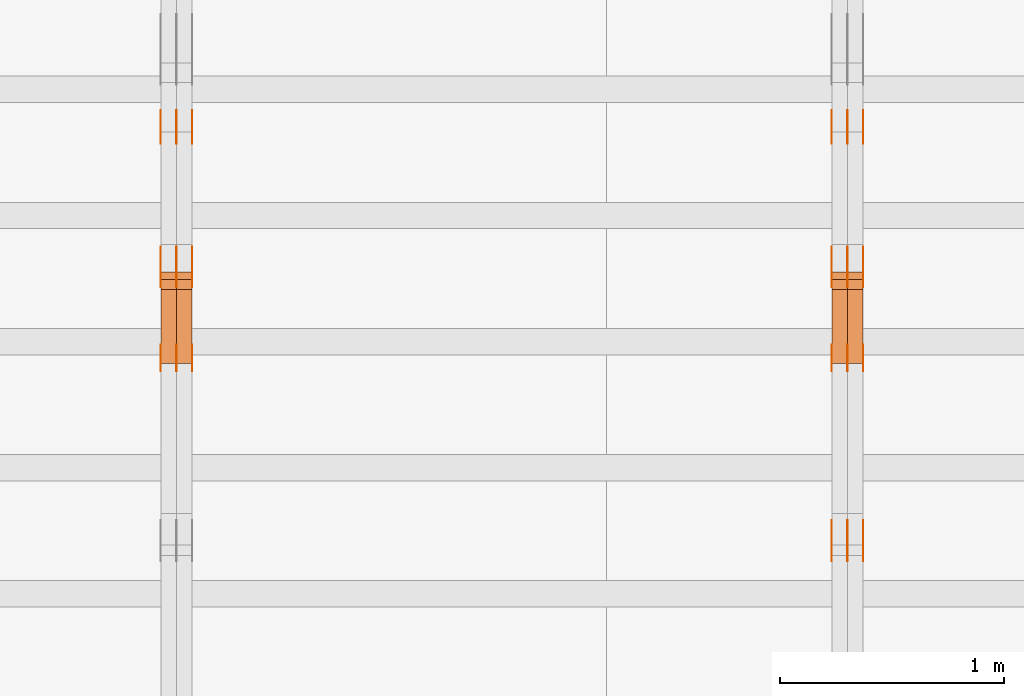
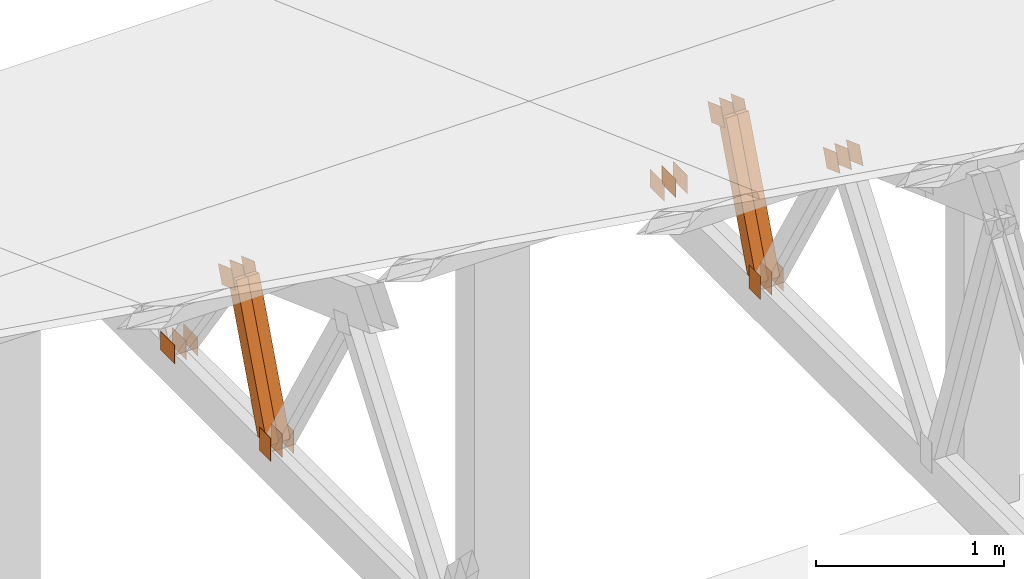
# One storey, part 127 of 189: 32 proxies.
"""IFC2X3 building model written with IfcOpenShell, lengths in millimetres."""

from ifc_helpers import new_model, entity, si_unit, converted_unit, derived_unit, direction, frame, frame_2d, origin, origin_2d_with_axis, place, context, subcontext, project, spatial, polyline, rectangle, outline, extrude, source, transform, mapped, material, type_object, type_shapes, element, save


model = new_model("IFC2X3")

# Units and contexts
model_context = context("Model", 3, precision=0.01, world=origin(), true_north=direction((6.12303176911189e-17, 1.0)))
body_context = subcontext(model_context, "Body", "Model", "MODEL_VIEW")
ifc_project = project(units=[si_unit("LENGTHUNIT", "METRE", prefix="MILLI"), si_unit("AREAUNIT", "SQUARE_METRE"), si_unit("VOLUMEUNIT", "CUBIC_METRE"), converted_unit("PLANEANGLEUNIT", "DEGREE", entity("IfcRatioMeasure", 0.0174532925199433), si_unit("PLANEANGLEUNIT", "RADIAN"), dimensions=[0, 0, 0, 0, 0, 0, 0]), si_unit("MASSUNIT", "GRAM", prefix="KILO"), derived_unit("MASSDENSITYUNIT", [(si_unit("MASSUNIT", "GRAM", prefix="KILO"), 1), (si_unit("LENGTHUNIT", "METRE"), -3)]), si_unit("TIMEUNIT", "SECOND"), si_unit("FREQUENCYUNIT", "HERTZ"), si_unit("THERMODYNAMICTEMPERATUREUNIT", "DEGREE_CELSIUS"), derived_unit("THERMALTRANSMITTANCEUNIT", [(si_unit("MASSUNIT", "GRAM", prefix="KILO"), 1), (si_unit("THERMODYNAMICTEMPERATUREUNIT", "KELVIN"), -1), (si_unit("TIMEUNIT", "SECOND"), -3)]), derived_unit("VOLUMETRICFLOWRATEUNIT", [(si_unit("LENGTHUNIT", "METRE"), 3), (si_unit("TIMEUNIT", "SECOND"), -1)]), si_unit("ELECTRICCURRENTUNIT", "AMPERE"), si_unit("ELECTRICVOLTAGEUNIT", "VOLT"), si_unit("POWERUNIT", "WATT"), si_unit("FORCEUNIT", "NEWTON"), si_unit("ILLUMINANCEUNIT", "LUX"), si_unit("LUMINOUSFLUXUNIT", "LUMEN"), si_unit("LUMINOUSINTENSITYUNIT", "CANDELA"), derived_unit("USERDEFINED", [(si_unit("MASSUNIT", "GRAM", prefix="KILO"), -1), (si_unit("LENGTHUNIT", "METRE"), -2), (si_unit("TIMEUNIT", "SECOND"), 3), (si_unit("LUMINOUSFLUXUNIT", "LUMEN"), 1)]), derived_unit("LINEARVELOCITYUNIT", [(si_unit("LENGTHUNIT", "METRE"), 1), (si_unit("TIMEUNIT", "SECOND"), -1)]), si_unit("PRESSUREUNIT", "PASCAL"), derived_unit("USERDEFINED", [(si_unit("LENGTHUNIT", "METRE"), -2), (si_unit("MASSUNIT", "GRAM", prefix="KILO"), 1), (si_unit("TIMEUNIT", "SECOND"), -2)])], contexts=[model_context])

# Site, building, storey
site_placement = place(None, origin())
site = spatial("IfcSite", under=ifc_project, at=site_placement, CompositionType="ELEMENT")
building_placement = place(site_placement, origin())
building = spatial("IfcBuilding", under=site, at=building_placement, CompositionType="ELEMENT")
storey_placement = place(building_placement, origin())
storey = spatial("IfcBuildingStorey", under=building, at=storey_placement, Name="Default", CompositionType="ELEMENT", Elevation=0.0)

# Proxies
ifc_material_1 = material(Name="IfcSurfaceStyle #105566")
building_element_proxy_type_1 = type_object("IfcBuildingElementProxyType", PredefinedType="NOTDEFINED", material=ifc_material_1)
shared_shape_1 = source(origin(), body_context, "Body", "SweptSolid", [
    extrude(outline(polyline([(-74.9999475298494, -60.0), (75.0000042257432, -60.0), (74.9999684051025, 60.0), (-75.0000251009963, 60.0), (-74.9999475298494, -60.0)])), frame((75.0000607644577, 60.0000865490217, 0.0), z_axis=(0.0, 0.0, 1.0), x_axis=(-1.0, 0.0, 0.0)), (0.0, 0.0, 1.0), 1.3),
])
type_shapes(building_element_proxy_type_1, [shared_shape_1])
proxy_1_placement = place(building_placement, frame((18301.3, 25732.0586805394, 1446.84420669249), z_axis=(-1.0, 0.0, 0.0), x_axis=(0.0, -0.939692620785908, 0.342020143325669)))
element("IfcBuildingElementProxy", 1, at=proxy_1_placement, inside=storey, type_object=building_element_proxy_type_1, material=ifc_material_1, context=body_context, shape_type="MappedRepresentation", body=[
    mapped(shared_shape_1, transform((0.0, 0.0, 0.0), scale=1.0)),
])
ifc_material_2 = material(Name="IfcSurfaceStyle #105509")
building_element_proxy_type_2 = type_object("IfcBuildingElementProxyType", PredefinedType="NOTDEFINED", material=ifc_material_2)
shared_shape_2 = source(origin(), body_context, "Body", "SweptSolid", [
    extrude(outline(polyline([(-74.9999475298494, -60.0), (75.0000042257432, -60.0), (74.9999684051025, 60.0), (-75.0000251009963, 60.0), (-74.9999475298494, -60.0)])), frame((75.0000607644577, 60.0000865490217, 0.0), z_axis=(0.0, 0.0, 1.0), x_axis=(-1.0, 0.0, 0.0)), (0.0, 0.0, 1.0), 1.29999999999999),
])
type_shapes(building_element_proxy_type_2, [shared_shape_2])
proxy_2_placement = place(building_placement, frame((18230.0, 25732.0586805394, 1446.84420669249), z_axis=(-1.0, 0.0, 0.0), x_axis=(0.0, -0.939692620785908, 0.342020143325669)))
element("IfcBuildingElementProxy", 2, at=proxy_2_placement, inside=storey, type_object=building_element_proxy_type_2, material=ifc_material_2, context=body_context, shape_type="MappedRepresentation", body=[
    mapped(shared_shape_2, transform((0.0, 0.0, 0.0), scale=1.0)),
])
ifc_material_3 = material(Name="IfcSurfaceStyle #105452")
building_element_proxy_type_3 = type_object("IfcBuildingElementProxyType", PredefinedType="NOTDEFINED", material=ifc_material_3)
shared_shape_3 = source(origin(), body_context, "Body", "SweptSolid", [
    extrude(outline(polyline([(-74.9999475298494, -60.0), (75.0000042257432, -60.0), (74.9999684051025, 60.0), (-75.0000251009963, 60.0), (-74.9999475298494, -60.0)])), frame((75.0000607644577, 60.0000865490217, 0.0), z_axis=(0.0, 0.0, 1.0), x_axis=(-1.0, 0.0, 0.0)), (0.0, 0.0, 1.0), 1.29999999999999),
])
type_shapes(building_element_proxy_type_3, [shared_shape_3])
proxy_3_placement = place(building_placement, frame((18231.3, 25732.0586805394, 1446.84420669249), z_axis=(-1.0, 0.0, 0.0), x_axis=(0.0, -0.939692620785908, 0.342020143325669)))
element("IfcBuildingElementProxy", 3, at=proxy_3_placement, inside=storey, type_object=building_element_proxy_type_3, material=ifc_material_3, context=body_context, shape_type="MappedRepresentation", body=[
    mapped(shared_shape_3, transform((0.0, 0.0, 0.0), scale=1.0)),
])
ifc_material_4 = material(Name="IfcSurfaceStyle #105395")
building_element_proxy_type_4 = type_object("IfcBuildingElementProxyType", PredefinedType="NOTDEFINED", material=ifc_material_4)
shared_shape_4 = source(origin(), body_context, "Body", "SweptSolid", [
    extrude(outline(polyline([(-74.9999475298494, -60.0), (75.0000042257432, -60.0), (74.9999684051025, 60.0), (-75.0000251009963, 60.0), (-74.9999475298494, -60.0)])), frame((75.0000607644577, 60.0000865490217, 0.0), z_axis=(0.0, 0.0, 1.0), x_axis=(-1.0, 0.0, 0.0)), (0.0, 0.0, 1.0), 1.29999999999999),
])
type_shapes(building_element_proxy_type_4, [shared_shape_4])
proxy_4_placement = place(building_placement, frame((18160.0, 25732.0586805394, 1446.84420669249), z_axis=(-1.0, 0.0, 0.0), x_axis=(0.0, -0.939692620785908, 0.342020143325669)))
element("IfcBuildingElementProxy", 4, at=proxy_4_placement, inside=storey, type_object=building_element_proxy_type_4, material=ifc_material_4, context=body_context, shape_type="MappedRepresentation", body=[
    mapped(shared_shape_4, transform((0.0, 0.0, 0.0), scale=1.0)),
])
ifc_material_5 = material(Name="IfcSurfaceStyle #105338")
building_element_proxy_type_5 = type_object("IfcBuildingElementProxyType", PredefinedType="NOTDEFINED", material=ifc_material_5)
shared_shape_5 = source(origin(), body_context, "Body", "SweptSolid", [
    extrude(rectangle(XDim=150.0, YDim=120.0, at=frame_2d((-7.105427357601e-15, 0.0), x_axis=(1.0, 0.0))), frame((75.0, 60.0, 0.0), z_axis=(0.0, 0.0, 1.0), x_axis=(-1.0, 0.0, 0.0)), (0.0, 0.0, 1.0), 1.3),
])
type_shapes(building_element_proxy_type_5, [shared_shape_5])
proxy_5_placement = place(building_placement, frame((18301.3, 26439.0083007813, 170.0), z_axis=(-1.0, 0.0, 0.0), x_axis=(0.0, 0.0, 1.0)))
element("IfcBuildingElementProxy", 5, at=proxy_5_placement, inside=storey, type_object=building_element_proxy_type_5, material=ifc_material_5, context=body_context, shape_type="MappedRepresentation", body=[
    mapped(shared_shape_5, transform((0.0, 0.0, 0.0), scale=1.0)),
])
ifc_material_6 = material(Name="IfcSurfaceStyle #105281")
building_element_proxy_type_6 = type_object("IfcBuildingElementProxyType", PredefinedType="NOTDEFINED", material=ifc_material_6)
shared_shape_6 = source(origin(), body_context, "Body", "SweptSolid", [
    extrude(rectangle(XDim=150.0, YDim=120.0, at=frame_2d((-7.105427357601e-15, 0.0), x_axis=(1.0, 0.0))), frame((75.0, 60.0, 0.0), z_axis=(0.0, 0.0, 1.0), x_axis=(-1.0, 0.0, 0.0)), (0.0, 0.0, 1.0), 1.29999999999999),
])
type_shapes(building_element_proxy_type_6, [shared_shape_6])
proxy_6_placement = place(building_placement, frame((18230.0, 26439.0083007813, 170.0), z_axis=(-1.0, 0.0, 0.0), x_axis=(0.0, 0.0, 1.0)))
element("IfcBuildingElementProxy", 6, at=proxy_6_placement, inside=storey, type_object=building_element_proxy_type_6, material=ifc_material_6, context=body_context, shape_type="MappedRepresentation", body=[
    mapped(shared_shape_6, transform((0.0, 0.0, 0.0), scale=1.0)),
])
ifc_material_7 = material(Name="IfcSurfaceStyle #105224")
building_element_proxy_type_7 = type_object("IfcBuildingElementProxyType", PredefinedType="NOTDEFINED", material=ifc_material_7)
shared_shape_7 = source(origin(), body_context, "Body", "SweptSolid", [
    extrude(rectangle(XDim=150.0, YDim=120.0, at=frame_2d((-7.105427357601e-15, 0.0), x_axis=(1.0, 0.0))), frame((75.0, 60.0, 0.0), z_axis=(0.0, 0.0, 1.0), x_axis=(-1.0, 0.0, 0.0)), (0.0, 0.0, 1.0), 1.29999999999999),
])
type_shapes(building_element_proxy_type_7, [shared_shape_7])
proxy_7_placement = place(building_placement, frame((18231.3, 26439.0083007813, 170.0), z_axis=(-1.0, 0.0, 0.0), x_axis=(0.0, 0.0, 1.0)))
element("IfcBuildingElementProxy", 7, at=proxy_7_placement, inside=storey, type_object=building_element_proxy_type_7, material=ifc_material_7, context=body_context, shape_type="MappedRepresentation", body=[
    mapped(shared_shape_7, transform((0.0, 0.0, 0.0), scale=1.0)),
])
ifc_material_8 = material(Name="IfcSurfaceStyle #105167")
building_element_proxy_type_8 = type_object("IfcBuildingElementProxyType", PredefinedType="NOTDEFINED", material=ifc_material_8)
shared_shape_8 = source(origin(), body_context, "Body", "SweptSolid", [
    extrude(rectangle(XDim=150.0, YDim=120.0, at=frame_2d((-7.105427357601e-15, 0.0), x_axis=(1.0, 0.0))), frame((75.0, 60.0, 0.0), z_axis=(0.0, 0.0, 1.0), x_axis=(-1.0, 0.0, 0.0)), (0.0, 0.0, 1.0), 1.29999999999999),
])
type_shapes(building_element_proxy_type_8, [shared_shape_8])
proxy_8_placement = place(building_placement, frame((18160.0, 26439.0083007813, 170.0), z_axis=(-1.0, 0.0, 0.0), x_axis=(0.0, 0.0, 1.0)))
element("IfcBuildingElementProxy", 8, at=proxy_8_placement, inside=storey, type_object=building_element_proxy_type_8, material=ifc_material_8, context=body_context, shape_type="MappedRepresentation", body=[
    mapped(shared_shape_8, transform((0.0, 0.0, 0.0), scale=1.0)),
])
ifc_material_9 = material(Name="IfcSurfaceStyle #104654")
building_element_proxy_type_9 = type_object("IfcBuildingElementProxyType", PredefinedType="NOTDEFINED", material=ifc_material_9)
shared_shape_9 = source(origin(), body_context, "Body", "SweptSolid", [
    extrude(outline(polyline([(-74.9999684051023, -60.0), (75.0000251009964, -60.0), (74.9999475298495, 60.0), (-75.0000042257435, 60.0), (-74.9999684051023, -60.0)])), frame((75.0000251009964, 60.0000006265238, 0.0), z_axis=(0.0, 0.0, 1.0), x_axis=(-1.0, 0.0, 0.0)), (0.0, 0.0, 1.0), 1.3),
])
type_shapes(building_element_proxy_type_9, [shared_shape_9])
proxy_9_placement = place(building_placement, frame((18301.3, 26956.490053282, 1001.18769055967), z_axis=(-1.0, 0.0, 0.0), x_axis=(0.0, -0.939692620785908, 0.342020143325669)))
element("IfcBuildingElementProxy", 9, at=proxy_9_placement, inside=storey, type_object=building_element_proxy_type_9, material=ifc_material_9, context=body_context, shape_type="MappedRepresentation", body=[
    mapped(shared_shape_9, transform((0.0, 0.0, 0.0), scale=1.0)),
])
ifc_material_10 = material(Name="IfcSurfaceStyle #104597")
building_element_proxy_type_10 = type_object("IfcBuildingElementProxyType", PredefinedType="NOTDEFINED", material=ifc_material_10)
shared_shape_10 = source(origin(), body_context, "Body", "SweptSolid", [
    extrude(outline(polyline([(-74.9999684051023, -60.0), (75.0000251009964, -60.0), (74.9999475298495, 60.0), (-75.0000042257435, 60.0), (-74.9999684051023, -60.0)])), frame((75.0000251009964, 60.0000006265238, 0.0), z_axis=(0.0, 0.0, 1.0), x_axis=(-1.0, 0.0, 0.0)), (0.0, 0.0, 1.0), 1.29999999999999),
])
type_shapes(building_element_proxy_type_10, [shared_shape_10])
proxy_10_placement = place(building_placement, frame((18230.0, 26956.490053282, 1001.18769055967), z_axis=(-1.0, 0.0, 0.0), x_axis=(0.0, -0.939692620785908, 0.342020143325669)))
element("IfcBuildingElementProxy", 10, at=proxy_10_placement, inside=storey, type_object=building_element_proxy_type_10, material=ifc_material_10, context=body_context, shape_type="MappedRepresentation", body=[
    mapped(shared_shape_10, transform((0.0, 0.0, 0.0), scale=1.0)),
])
ifc_material_11 = material(Name="IfcSurfaceStyle #104540")
building_element_proxy_type_11 = type_object("IfcBuildingElementProxyType", PredefinedType="NOTDEFINED", material=ifc_material_11)
shared_shape_11 = source(origin(), body_context, "Body", "SweptSolid", [
    extrude(outline(polyline([(-74.9999684051023, -60.0), (75.0000251009964, -60.0), (74.9999475298495, 60.0), (-75.0000042257435, 60.0), (-74.9999684051023, -60.0)])), frame((75.0000251009964, 60.0000006265238, 0.0), z_axis=(0.0, 0.0, 1.0), x_axis=(-1.0, 0.0, 0.0)), (0.0, 0.0, 1.0), 1.29999999999999),
])
type_shapes(building_element_proxy_type_11, [shared_shape_11])
proxy_11_placement = place(building_placement, frame((18231.3, 26956.490053282, 1001.18769055967), z_axis=(-1.0, 0.0, 0.0), x_axis=(0.0, -0.939692620785908, 0.342020143325669)))
element("IfcBuildingElementProxy", 11, at=proxy_11_placement, inside=storey, type_object=building_element_proxy_type_11, material=ifc_material_11, context=body_context, shape_type="MappedRepresentation", body=[
    mapped(shared_shape_11, transform((0.0, 0.0, 0.0), scale=1.0)),
])
ifc_material_12 = material(Name="IfcSurfaceStyle #104483")
building_element_proxy_type_12 = type_object("IfcBuildingElementProxyType", PredefinedType="NOTDEFINED", material=ifc_material_12)
shared_shape_12 = source(origin(), body_context, "Body", "SweptSolid", [
    extrude(outline(polyline([(-74.9999684051023, -60.0), (75.0000251009964, -60.0), (74.9999475298495, 60.0), (-75.0000042257435, 60.0), (-74.9999684051023, -60.0)])), frame((75.0000251009964, 60.0000006265238, 0.0), z_axis=(0.0, 0.0, 1.0), x_axis=(-1.0, 0.0, 0.0)), (0.0, 0.0, 1.0), 1.29999999999999),
])
type_shapes(building_element_proxy_type_12, [shared_shape_12])
proxy_12_placement = place(building_placement, frame((18160.0, 26956.490053282, 1001.18769055967), z_axis=(-1.0, 0.0, 0.0), x_axis=(0.0, -0.939692620785908, 0.342020143325669)))
element("IfcBuildingElementProxy", 12, at=proxy_12_placement, inside=storey, type_object=building_element_proxy_type_12, material=ifc_material_12, context=body_context, shape_type="MappedRepresentation", body=[
    mapped(shared_shape_12, transform((0.0, 0.0, 0.0), scale=1.0)),
])
ifc_material_13 = material(Name="IfcSurfaceStyle #104426")
building_element_proxy_type_13 = type_object("IfcBuildingElementProxyType", PredefinedType="NOTDEFINED", material=ifc_material_13)
shared_shape_13 = source(origin(), body_context, "Body", "SweptSolid", [
    extrude(rectangle(XDim=150.0, YDim=120.0, at=origin_2d_with_axis()), frame((75.0, 60.0, 0.0), z_axis=(0.0, 0.0, 1.0), x_axis=(-1.0, 0.0, 0.0)), (0.0, 0.0, 1.0), 1.3),
])
type_shapes(building_element_proxy_type_13, [shared_shape_13])
proxy_13_placement = place(building_placement, frame((18301.3, 27607.3129882813, 185.0), z_axis=(-1.0, 0.0, 0.0), x_axis=(0.0, -1.0, 0.0)))
element("IfcBuildingElementProxy", 13, at=proxy_13_placement, inside=storey, type_object=building_element_proxy_type_13, material=ifc_material_13, context=body_context, shape_type="MappedRepresentation", body=[
    mapped(shared_shape_13, transform((0.0, 0.0, 0.0), scale=1.0)),
])
ifc_material_14 = material(Name="IfcSurfaceStyle #104369")
building_element_proxy_type_14 = type_object("IfcBuildingElementProxyType", PredefinedType="NOTDEFINED", material=ifc_material_14)
shared_shape_14 = source(origin(), body_context, "Body", "SweptSolid", [
    extrude(rectangle(XDim=150.0, YDim=120.0, at=origin_2d_with_axis()), frame((75.0, 60.0, 0.0), z_axis=(0.0, 0.0, 1.0), x_axis=(-1.0, 0.0, 0.0)), (0.0, 0.0, 1.0), 1.29999999999999),
])
type_shapes(building_element_proxy_type_14, [shared_shape_14])
proxy_14_placement = place(building_placement, frame((18230.0, 27607.3129882813, 185.0), z_axis=(-1.0, 0.0, 0.0), x_axis=(0.0, -1.0, 0.0)))
element("IfcBuildingElementProxy", 14, at=proxy_14_placement, inside=storey, type_object=building_element_proxy_type_14, material=ifc_material_14, context=body_context, shape_type="MappedRepresentation", body=[
    mapped(shared_shape_14, transform((0.0, 0.0, 0.0), scale=1.0)),
])
ifc_material_15 = material(Name="IfcSurfaceStyle #104312")
building_element_proxy_type_15 = type_object("IfcBuildingElementProxyType", PredefinedType="NOTDEFINED", material=ifc_material_15)
shared_shape_15 = source(origin(), body_context, "Body", "SweptSolid", [
    extrude(rectangle(XDim=150.0, YDim=120.0, at=origin_2d_with_axis()), frame((75.0, 60.0, 0.0), z_axis=(0.0, 0.0, 1.0), x_axis=(-1.0, 0.0, 0.0)), (0.0, 0.0, 1.0), 1.29999999999999),
])
type_shapes(building_element_proxy_type_15, [shared_shape_15])
proxy_15_placement = place(building_placement, frame((18231.3, 27607.3129882813, 185.0), z_axis=(-1.0, 0.0, 0.0), x_axis=(0.0, -1.0, 0.0)))
element("IfcBuildingElementProxy", 15, at=proxy_15_placement, inside=storey, type_object=building_element_proxy_type_15, material=ifc_material_15, context=body_context, shape_type="MappedRepresentation", body=[
    mapped(shared_shape_15, transform((0.0, 0.0, 0.0), scale=1.0)),
])
ifc_material_16 = material(Name="IfcSurfaceStyle #104255")
building_element_proxy_type_16 = type_object("IfcBuildingElementProxyType", PredefinedType="NOTDEFINED", material=ifc_material_16)
shared_shape_16 = source(origin(), body_context, "Body", "SweptSolid", [
    extrude(rectangle(XDim=150.0, YDim=120.0, at=origin_2d_with_axis()), frame((75.0, 60.0, 0.0), z_axis=(0.0, 0.0, 1.0), x_axis=(-1.0, 0.0, 0.0)), (0.0, 0.0, 1.0), 1.29999999999999),
])
type_shapes(building_element_proxy_type_16, [shared_shape_16])
proxy_16_placement = place(building_placement, frame((18160.0, 27607.3129882813, 185.0), z_axis=(-1.0, 0.0, 0.0), x_axis=(0.0, -1.0, 0.0)))
element("IfcBuildingElementProxy", 16, at=proxy_16_placement, inside=storey, type_object=building_element_proxy_type_16, material=ifc_material_16, context=body_context, shape_type="MappedRepresentation", body=[
    mapped(shared_shape_16, transform((0.0, 0.0, 0.0), scale=1.0)),
])
ifc_material_17 = material(Name="IfcSurfaceStyle #97178")
building_element_proxy_type_17 = type_object("IfcBuildingElementProxyType", Name="T1-W14 97176", PredefinedType="NOTDEFINED", material=ifc_material_17)
shared_shape_17 = source(origin(), body_context, "Body", "SweptSolid", [
    extrude(outline(polyline([(-561.981237417233, -47.499947472121), (373.092610496013, -47.499947472121), (373.679602940405, -4.61719047935016e-05), (341.277449358876, 47.4999705580734), (-526.068425378061, 47.4999705580734), (-561.981237417233, -47.499947472121)])), frame((373.679632439416, 47.500120814091, 0.0), z_axis=(0.0, 0.0, 1.0), x_axis=(-1.0, 0.0, 0.0)), (0.0, 0.0, 1.0), 69.9999999999999),
])
type_shapes(building_element_proxy_type_17, [shared_shape_17])
proxy_17_placement = place(building_placement, frame((18300.0, 26895.4809555667, 1086.61918844835), z_axis=(-1.0, 0.0, 0.0), x_axis=(0.0, -0.353606472447933, -0.935394281916951)))
element("IfcBuildingElementProxy", 17, at=proxy_17_placement, inside=storey, type_object=building_element_proxy_type_17, material=ifc_material_17, Name="T1-W14", context=body_context, shape_type="MappedRepresentation", body=[
    mapped(shared_shape_17, transform((0.0, 0.0, 0.0), scale=1.0)),
])
ifc_material_18 = material(Name="IfcSurfaceStyle #97112")
building_element_proxy_type_18 = type_object("IfcBuildingElementProxyType", Name="T1-W14 97110", PredefinedType="NOTDEFINED", material=ifc_material_18)
shared_shape_18 = source(origin(), body_context, "Body", "SweptSolid", [
    extrude(outline(polyline([(-561.981237417233, -47.499947472121), (373.092610496013, -47.499947472121), (373.679602940405, -4.61719047935016e-05), (341.277449358876, 47.4999705580734), (-526.068425378061, 47.4999705580734), (-561.981237417233, -47.499947472121)])), frame((373.679632439416, 47.500120814091, 0.0), z_axis=(0.0, 0.0, 1.0), x_axis=(-1.0, 0.0, 0.0)), (0.0, 0.0, 1.0), 69.9999999999999),
])
type_shapes(building_element_proxy_type_18, [shared_shape_18])
proxy_18_placement = place(building_placement, frame((18230.0, 26895.4809555667, 1086.61918844835), z_axis=(-1.0, 0.0, 0.0), x_axis=(0.0, -0.353606472447933, -0.935394281916951)))
element("IfcBuildingElementProxy", 18, at=proxy_18_placement, inside=storey, type_object=building_element_proxy_type_18, material=ifc_material_18, Name="T1-W14", context=body_context, shape_type="MappedRepresentation", body=[
    mapped(shared_shape_18, transform((0.0, 0.0, 0.0), scale=1.0)),
])
ifc_material_19 = material(Name="IfcSurfaceStyle #89548")
building_element_proxy_type_19 = type_object("IfcBuildingElementProxyType", PredefinedType="NOTDEFINED", material=ifc_material_19)
shared_shape_19 = source(origin(), body_context, "Body", "SweptSolid", [
    extrude(rectangle(XDim=150.0, YDim=120.0, at=frame_2d((-7.105427357601e-15, 0.0), x_axis=(1.0, 0.0))), frame((75.0, 60.0, 0.0), z_axis=(0.0, 0.0, 1.0), x_axis=(-1.0, 0.0, 0.0)), (0.0, 0.0, 1.0), 1.3),
])
type_shapes(building_element_proxy_type_19, [shared_shape_19])
proxy_19_placement = place(building_placement, frame((15301.3, 26439.0083007813, 170.0), z_axis=(-1.0, 0.0, 0.0), x_axis=(0.0, 0.0, 1.0)))
element("IfcBuildingElementProxy", 19, at=proxy_19_placement, inside=storey, type_object=building_element_proxy_type_19, material=ifc_material_19, context=body_context, shape_type="MappedRepresentation", body=[
    mapped(shared_shape_19, transform((0.0, 0.0, 0.0), scale=1.0)),
])
ifc_material_20 = material(Name="IfcSurfaceStyle #89491")
building_element_proxy_type_20 = type_object("IfcBuildingElementProxyType", PredefinedType="NOTDEFINED", material=ifc_material_20)
shared_shape_20 = source(origin(), body_context, "Body", "SweptSolid", [
    extrude(rectangle(XDim=150.0, YDim=120.0, at=frame_2d((-7.105427357601e-15, 0.0), x_axis=(1.0, 0.0))), frame((75.0, 60.0, 0.0), z_axis=(0.0, 0.0, 1.0), x_axis=(-1.0, 0.0, 0.0)), (0.0, 0.0, 1.0), 1.29999999999999),
])
type_shapes(building_element_proxy_type_20, [shared_shape_20])
proxy_20_placement = place(building_placement, frame((15230.0, 26439.0083007813, 170.0), z_axis=(-1.0, 0.0, 0.0), x_axis=(0.0, 0.0, 1.0)))
element("IfcBuildingElementProxy", 20, at=proxy_20_placement, inside=storey, type_object=building_element_proxy_type_20, material=ifc_material_20, context=body_context, shape_type="MappedRepresentation", body=[
    mapped(shared_shape_20, transform((0.0, 0.0, 0.0), scale=1.0)),
])
ifc_material_21 = material(Name="IfcSurfaceStyle #89434")
building_element_proxy_type_21 = type_object("IfcBuildingElementProxyType", PredefinedType="NOTDEFINED", material=ifc_material_21)
shared_shape_21 = source(origin(), body_context, "Body", "SweptSolid", [
    extrude(rectangle(XDim=150.0, YDim=120.0, at=frame_2d((-7.105427357601e-15, 0.0), x_axis=(1.0, 0.0))), frame((75.0, 60.0, 0.0), z_axis=(0.0, 0.0, 1.0), x_axis=(-1.0, 0.0, 0.0)), (0.0, 0.0, 1.0), 1.29999999999999),
])
type_shapes(building_element_proxy_type_21, [shared_shape_21])
proxy_21_placement = place(building_placement, frame((15231.3, 26439.0083007813, 170.0), z_axis=(-1.0, 0.0, 0.0), x_axis=(0.0, 0.0, 1.0)))
element("IfcBuildingElementProxy", 21, at=proxy_21_placement, inside=storey, type_object=building_element_proxy_type_21, material=ifc_material_21, context=body_context, shape_type="MappedRepresentation", body=[
    mapped(shared_shape_21, transform((0.0, 0.0, 0.0), scale=1.0)),
])
ifc_material_22 = material(Name="IfcSurfaceStyle #89377")
building_element_proxy_type_22 = type_object("IfcBuildingElementProxyType", PredefinedType="NOTDEFINED", material=ifc_material_22)
shared_shape_22 = source(origin(), body_context, "Body", "SweptSolid", [
    extrude(rectangle(XDim=150.0, YDim=120.0, at=frame_2d((-7.105427357601e-15, 0.0), x_axis=(1.0, 0.0))), frame((75.0, 60.0, 0.0), z_axis=(0.0, 0.0, 1.0), x_axis=(-1.0, 0.0, 0.0)), (0.0, 0.0, 1.0), 1.29999999999999),
])
type_shapes(building_element_proxy_type_22, [shared_shape_22])
proxy_22_placement = place(building_placement, frame((15160.0, 26439.0083007813, 170.0), z_axis=(-1.0, 0.0, 0.0), x_axis=(0.0, 0.0, 1.0)))
element("IfcBuildingElementProxy", 22, at=proxy_22_placement, inside=storey, type_object=building_element_proxy_type_22, material=ifc_material_22, context=body_context, shape_type="MappedRepresentation", body=[
    mapped(shared_shape_22, transform((0.0, 0.0, 0.0), scale=1.0)),
])
ifc_material_23 = material(Name="IfcSurfaceStyle #88864")
building_element_proxy_type_23 = type_object("IfcBuildingElementProxyType", PredefinedType="NOTDEFINED", material=ifc_material_23)
shared_shape_23 = source(origin(), body_context, "Body", "SweptSolid", [
    extrude(outline(polyline([(-74.9999684051023, -60.0), (75.0000251009964, -60.0), (74.9999475298495, 60.0), (-75.0000042257435, 60.0), (-74.9999684051023, -60.0)])), frame((75.0000251009964, 60.0000006265238, 0.0), z_axis=(0.0, 0.0, 1.0), x_axis=(-1.0, 0.0, 0.0)), (0.0, 0.0, 1.0), 1.3),
])
type_shapes(building_element_proxy_type_23, [shared_shape_23])
proxy_23_placement = place(building_placement, frame((15301.3, 26956.490053282, 1001.18769055967), z_axis=(-1.0, 0.0, 0.0), x_axis=(0.0, -0.939692620785908, 0.342020143325669)))
element("IfcBuildingElementProxy", 23, at=proxy_23_placement, inside=storey, type_object=building_element_proxy_type_23, material=ifc_material_23, context=body_context, shape_type="MappedRepresentation", body=[
    mapped(shared_shape_23, transform((0.0, 0.0, 0.0), scale=1.0)),
])
ifc_material_24 = material(Name="IfcSurfaceStyle #88807")
building_element_proxy_type_24 = type_object("IfcBuildingElementProxyType", PredefinedType="NOTDEFINED", material=ifc_material_24)
shared_shape_24 = source(origin(), body_context, "Body", "SweptSolid", [
    extrude(outline(polyline([(-74.9999684051023, -60.0), (75.0000251009964, -60.0), (74.9999475298495, 60.0), (-75.0000042257435, 60.0), (-74.9999684051023, -60.0)])), frame((75.0000251009964, 60.0000006265238, 0.0), z_axis=(0.0, 0.0, 1.0), x_axis=(-1.0, 0.0, 0.0)), (0.0, 0.0, 1.0), 1.29999999999999),
])
type_shapes(building_element_proxy_type_24, [shared_shape_24])
proxy_24_placement = place(building_placement, frame((15230.0, 26956.490053282, 1001.18769055967), z_axis=(-1.0, 0.0, 0.0), x_axis=(0.0, -0.939692620785908, 0.342020143325669)))
element("IfcBuildingElementProxy", 24, at=proxy_24_placement, inside=storey, type_object=building_element_proxy_type_24, material=ifc_material_24, context=body_context, shape_type="MappedRepresentation", body=[
    mapped(shared_shape_24, transform((0.0, 0.0, 0.0), scale=1.0)),
])
ifc_material_25 = material(Name="IfcSurfaceStyle #88750")
building_element_proxy_type_25 = type_object("IfcBuildingElementProxyType", PredefinedType="NOTDEFINED", material=ifc_material_25)
shared_shape_25 = source(origin(), body_context, "Body", "SweptSolid", [
    extrude(outline(polyline([(-74.9999684051023, -60.0), (75.0000251009964, -60.0), (74.9999475298495, 60.0), (-75.0000042257435, 60.0), (-74.9999684051023, -60.0)])), frame((75.0000251009964, 60.0000006265238, 0.0), z_axis=(0.0, 0.0, 1.0), x_axis=(-1.0, 0.0, 0.0)), (0.0, 0.0, 1.0), 1.29999999999999),
])
type_shapes(building_element_proxy_type_25, [shared_shape_25])
proxy_25_placement = place(building_placement, frame((15231.3, 26956.490053282, 1001.18769055967), z_axis=(-1.0, 0.0, 0.0), x_axis=(0.0, -0.939692620785908, 0.342020143325669)))
element("IfcBuildingElementProxy", 25, at=proxy_25_placement, inside=storey, type_object=building_element_proxy_type_25, material=ifc_material_25, context=body_context, shape_type="MappedRepresentation", body=[
    mapped(shared_shape_25, transform((0.0, 0.0, 0.0), scale=1.0)),
])
ifc_material_26 = material(Name="IfcSurfaceStyle #88693")
building_element_proxy_type_26 = type_object("IfcBuildingElementProxyType", PredefinedType="NOTDEFINED", material=ifc_material_26)
shared_shape_26 = source(origin(), body_context, "Body", "SweptSolid", [
    extrude(outline(polyline([(-74.9999684051023, -60.0), (75.0000251009964, -60.0), (74.9999475298495, 60.0), (-75.0000042257435, 60.0), (-74.9999684051023, -60.0)])), frame((75.0000251009964, 60.0000006265238, 0.0), z_axis=(0.0, 0.0, 1.0), x_axis=(-1.0, 0.0, 0.0)), (0.0, 0.0, 1.0), 1.29999999999999),
])
type_shapes(building_element_proxy_type_26, [shared_shape_26])
proxy_26_placement = place(building_placement, frame((15160.0, 26956.490053282, 1001.18769055967), z_axis=(-1.0, 0.0, 0.0), x_axis=(0.0, -0.939692620785908, 0.342020143325669)))
element("IfcBuildingElementProxy", 26, at=proxy_26_placement, inside=storey, type_object=building_element_proxy_type_26, material=ifc_material_26, context=body_context, shape_type="MappedRepresentation", body=[
    mapped(shared_shape_26, transform((0.0, 0.0, 0.0), scale=1.0)),
])
ifc_material_27 = material(Name="IfcSurfaceStyle #88636")
building_element_proxy_type_27 = type_object("IfcBuildingElementProxyType", PredefinedType="NOTDEFINED", material=ifc_material_27)
shared_shape_27 = source(origin(), body_context, "Body", "SweptSolid", [
    extrude(rectangle(XDim=150.0, YDim=120.0, at=origin_2d_with_axis()), frame((75.0, 60.0, 0.0), z_axis=(0.0, 0.0, 1.0), x_axis=(-1.0, 0.0, 0.0)), (0.0, 0.0, 1.0), 1.3),
])
type_shapes(building_element_proxy_type_27, [shared_shape_27])
proxy_27_placement = place(building_placement, frame((15301.3, 27607.3129882813, 185.0), z_axis=(-1.0, 0.0, 0.0), x_axis=(0.0, -1.0, 0.0)))
element("IfcBuildingElementProxy", 27, at=proxy_27_placement, inside=storey, type_object=building_element_proxy_type_27, material=ifc_material_27, context=body_context, shape_type="MappedRepresentation", body=[
    mapped(shared_shape_27, transform((0.0, 0.0, 0.0), scale=1.0)),
])
ifc_material_28 = material(Name="IfcSurfaceStyle #88579")
building_element_proxy_type_28 = type_object("IfcBuildingElementProxyType", PredefinedType="NOTDEFINED", material=ifc_material_28)
shared_shape_28 = source(origin(), body_context, "Body", "SweptSolid", [
    extrude(rectangle(XDim=150.0, YDim=120.0, at=origin_2d_with_axis()), frame((75.0, 60.0, 0.0), z_axis=(0.0, 0.0, 1.0), x_axis=(-1.0, 0.0, 0.0)), (0.0, 0.0, 1.0), 1.29999999999999),
])
type_shapes(building_element_proxy_type_28, [shared_shape_28])
proxy_28_placement = place(building_placement, frame((15230.0, 27607.3129882813, 185.0), z_axis=(-1.0, 0.0, 0.0), x_axis=(0.0, -1.0, 0.0)))
element("IfcBuildingElementProxy", 28, at=proxy_28_placement, inside=storey, type_object=building_element_proxy_type_28, material=ifc_material_28, context=body_context, shape_type="MappedRepresentation", body=[
    mapped(shared_shape_28, transform((0.0, 0.0, 0.0), scale=1.0)),
])
ifc_material_29 = material(Name="IfcSurfaceStyle #88522")
building_element_proxy_type_29 = type_object("IfcBuildingElementProxyType", PredefinedType="NOTDEFINED", material=ifc_material_29)
shared_shape_29 = source(origin(), body_context, "Body", "SweptSolid", [
    extrude(rectangle(XDim=150.0, YDim=120.0, at=origin_2d_with_axis()), frame((75.0, 60.0, 0.0), z_axis=(0.0, 0.0, 1.0), x_axis=(-1.0, 0.0, 0.0)), (0.0, 0.0, 1.0), 1.29999999999999),
])
type_shapes(building_element_proxy_type_29, [shared_shape_29])
proxy_29_placement = place(building_placement, frame((15231.3, 27607.3129882813, 185.0), z_axis=(-1.0, 0.0, 0.0), x_axis=(0.0, -1.0, 0.0)))
element("IfcBuildingElementProxy", 29, at=proxy_29_placement, inside=storey, type_object=building_element_proxy_type_29, material=ifc_material_29, context=body_context, shape_type="MappedRepresentation", body=[
    mapped(shared_shape_29, transform((0.0, 0.0, 0.0), scale=1.0)),
])
ifc_material_30 = material(Name="IfcSurfaceStyle #88465")
building_element_proxy_type_30 = type_object("IfcBuildingElementProxyType", PredefinedType="NOTDEFINED", material=ifc_material_30)
shared_shape_30 = source(origin(), body_context, "Body", "SweptSolid", [
    extrude(rectangle(XDim=150.0, YDim=120.0, at=origin_2d_with_axis()), frame((75.0, 60.0, 0.0), z_axis=(0.0, 0.0, 1.0), x_axis=(-1.0, 0.0, 0.0)), (0.0, 0.0, 1.0), 1.29999999999999),
])
type_shapes(building_element_proxy_type_30, [shared_shape_30])
proxy_30_placement = place(building_placement, frame((15160.0, 27607.3129882813, 185.0), z_axis=(-1.0, 0.0, 0.0), x_axis=(0.0, -1.0, 0.0)))
element("IfcBuildingElementProxy", 30, at=proxy_30_placement, inside=storey, type_object=building_element_proxy_type_30, material=ifc_material_30, context=body_context, shape_type="MappedRepresentation", body=[
    mapped(shared_shape_30, transform((0.0, 0.0, 0.0), scale=1.0)),
])
ifc_material_31 = material(Name="IfcSurfaceStyle #81388")
building_element_proxy_type_31 = type_object("IfcBuildingElementProxyType", Name="T1-W14 81386", PredefinedType="NOTDEFINED", material=ifc_material_31)
shared_shape_31 = source(origin(), body_context, "Body", "SweptSolid", [
    extrude(outline(polyline([(-561.981237417233, -47.499947472121), (373.092610496013, -47.499947472121), (373.679602940405, -4.61719047935016e-05), (341.277449358876, 47.4999705580734), (-526.068425378061, 47.4999705580734), (-561.981237417233, -47.499947472121)])), frame((373.679632439416, 47.500120814091, 0.0), z_axis=(0.0, 0.0, 1.0), x_axis=(-1.0, 0.0, 0.0)), (0.0, 0.0, 1.0), 69.9999999999999),
])
type_shapes(building_element_proxy_type_31, [shared_shape_31])
proxy_31_placement = place(building_placement, frame((15300.0, 26895.4809555667, 1086.61918844835), z_axis=(-1.0, 0.0, 0.0), x_axis=(0.0, -0.353606472447933, -0.935394281916951)))
element("IfcBuildingElementProxy", 31, at=proxy_31_placement, inside=storey, type_object=building_element_proxy_type_31, material=ifc_material_31, Name="T1-W14", context=body_context, shape_type="MappedRepresentation", body=[
    mapped(shared_shape_31, transform((0.0, 0.0, 0.0), scale=1.0)),
])
ifc_material_32 = material(Name="IfcSurfaceStyle #81322")
building_element_proxy_type_32 = type_object("IfcBuildingElementProxyType", Name="T1-W14 81320", PredefinedType="NOTDEFINED", material=ifc_material_32)
shared_shape_32 = source(origin(), body_context, "Body", "SweptSolid", [
    extrude(outline(polyline([(-561.981237417233, -47.499947472121), (373.092610496013, -47.499947472121), (373.679602940405, -4.61719047935016e-05), (341.277449358876, 47.4999705580734), (-526.068425378061, 47.4999705580734), (-561.981237417233, -47.499947472121)])), frame((373.679632439416, 47.500120814091, 0.0), z_axis=(0.0, 0.0, 1.0), x_axis=(-1.0, 0.0, 0.0)), (0.0, 0.0, 1.0), 69.9999999999999),
])
type_shapes(building_element_proxy_type_32, [shared_shape_32])
proxy_32_placement = place(building_placement, frame((15230.0, 26895.4809555667, 1086.61918844835), z_axis=(-1.0, 0.0, 0.0), x_axis=(0.0, -0.353606472447933, -0.935394281916951)))
element("IfcBuildingElementProxy", 32, at=proxy_32_placement, inside=storey, type_object=building_element_proxy_type_32, material=ifc_material_32, Name="T1-W14", context=body_context, shape_type="MappedRepresentation", body=[
    mapped(shared_shape_32, transform((0.0, 0.0, 0.0), scale=1.0)),
])

save(model, "model.ifc")
